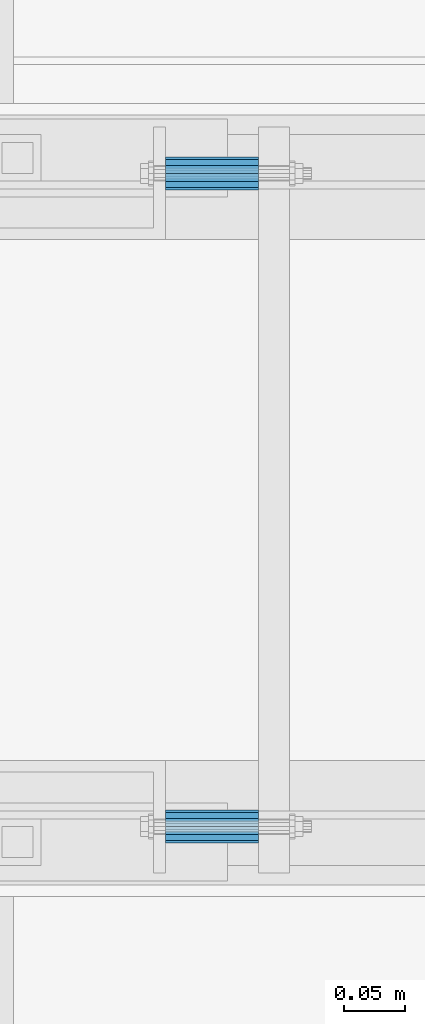
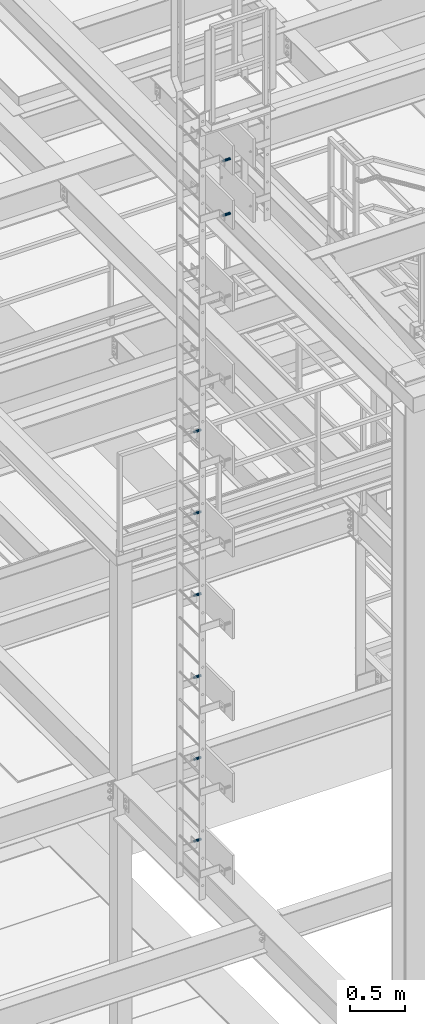
# One storey, part 2808 of 3843: 8 beams, 8 elements without a shape of their own.
"""IFC2X3 building model written with IfcOpenShell, lengths in millimetres."""

from ifc_helpers import new_model, si_unit, frame, origin_with_axes, place, context, subcontext, project, spatial, faceted_brep, material, type_object, element, aggregate, save


model = new_model("IFC2X3")

# Units and contexts
model_context = context("Model", 3, precision=1e-05, world=origin_with_axes())
body_context = subcontext(model_context, "Body", "Model", "MODEL_VIEW")
ifc_project = project(units=[si_unit("LENGTHUNIT", "METRE", prefix="MILLI"), si_unit("AREAUNIT", "SQUARE_METRE"), si_unit("VOLUMEUNIT", "CUBIC_METRE"), si_unit("MASSUNIT", "GRAM", prefix="KILO"), si_unit("TIMEUNIT", "SECOND"), si_unit("PLANEANGLEUNIT", "RADIAN"), si_unit("SOLIDANGLEUNIT", "STERADIAN"), si_unit("THERMODYNAMICTEMPERATUREUNIT", "DEGREE_CELSIUS"), si_unit("LUMINOUSINTENSITYUNIT", "LUMEN")], contexts=[model_context])

# Site, building, storey
site_placement = place(None, origin_with_axes())
site = spatial("IfcSite", under=ifc_project, at=site_placement, CompositionType="ELEMENT")
building_placement = place(site_placement, origin_with_axes())
building = spatial("IfcBuilding", under=site, at=building_placement, Name="Undefined", CompositionType="ELEMENT")
storey_placement = place(building_placement, origin_with_axes())
storey = spatial("IfcBuildingStorey", under=building, at=storey_placement, Name="Undefined", CompositionType="ELEMENT", Elevation=0.0)

# Assembly, beam
assembly_1_placement = place(storey_placement, origin_with_axes())
assembly_1 = element("IfcElementAssembly", 1, at=assembly_1_placement, inside=storey, Name="SLEEVE", AssemblyPlace="NOTDEFINED", PredefinedType="RIGID_FRAME")
ifc_material = material()
beam_type = type_object("IfcBeamType", Name="PIPE3/4SCH40", PredefinedType="NOTDEFINED")
beam_1_placement = place(assembly_1_placement, frame((48390.1749877929, 17919.6999999995, 35706.05), z_axis=(0.0, 0.0, 1.0), x_axis=(1.0, 0.0, 0.0)))
beam_1 = element("IfcBeam", 2, at=beam_1_placement, type_object=beam_type, material=ifc_material, Name="SLEEVE", ObjectType="PIPE3/4SCH40", context=body_context, shape_type="Brep", body=[
    faceted_brep([(0.0, -10.4648000000016, 7.27595761418343e-12), (-7.27595761418343e-12, -9.06278264552384, 5.23240000000806), (76.2000000004009, -9.06278264552384, 5.2324000001172), (76.2000000004045, -10.4648000000016, 1.16415321826935e-10), (-1.45519152283669e-11, -5.23240000000078, 9.06278264553839), (76.20000000039, -5.23240000000078, 9.06278264564753), (-1.45519152283669e-11, 0.0, 10.4648000000161), (76.20000000039, 0.0, 10.4648000001253), (-1.45519152283669e-11, 5.23240000000078, 9.06278264553839), (76.20000000039, 5.23240000000078, 9.06278264564753), (-7.27595761418343e-12, 9.06278264552384, 5.23240000000806), (76.2000000004009, 9.06278264552384, 5.2324000001172), (0.0, 10.4648000000016, 7.27595761418343e-12), (76.2000000004045, 10.4648000000016, 1.16415321826935e-10), (1.09139364212751e-11, 9.06278264552384, -5.2323999999935), (76.2000000004155, 9.06278264552384, -5.23239999988436), (1.45519152283669e-11, 5.23240000000078, -9.06278264551656), (76.2000000004191, 5.23240000000078, -9.06278264540742), (1.45519152283669e-11, 0.0, -10.4647999999943), (76.2000000004191, 0.0, -10.4647999998851), (1.45519152283669e-11, -5.23240000000078, -9.06278264551656), (76.2000000004191, -5.23240000000078, -9.06278264540742), (1.09139364212751e-11, -9.06278264552384, -5.2323999999935), (76.2000000004155, -9.06278264552384, -5.23239999988436), (0.0, -13.3349999999991, 7.27595761418343e-12), (1.09139364212751e-11, -11.5484487594658, -6.66749999999593), (76.2000000004155, -11.5484487594658, -6.66749999988679), (76.2000000004045, -13.3349999999991, 1.16415321826935e-10), (1.45519152283669e-11, -6.66749999999956, -11.5484487594586), (76.2000000004191, -6.66749999999956, -11.5484487593494), (1.81898940354586e-11, 0.0, -13.3349999999919), (76.2000000004227, 0.0, -13.3349999998827), (1.45519152283669e-11, 6.66749999999956, -11.5484487594586), (76.2000000004191, 6.66749999999956, -11.5484487593494), (1.09139364212751e-11, 11.5484487594658, -6.66749999999593), (76.2000000004155, 11.5484487594658, -6.66749999988679), (0.0, 13.3349999999991, 7.27595761418343e-12), (76.2000000004045, 13.3349999999991, 1.16415321826935e-10), (-7.27595761418343e-12, 11.5484487594658, 6.66750000001048), (76.2000000003973, 11.5484487594658, 6.66750000011234), (-1.45519152283669e-11, 6.66749999999956, 11.5484487594804), (76.20000000039, 6.66749999999956, 11.5484487595895), (-1.81898940354586e-11, 0.0, 13.3350000000137), (76.2000000003864, 0.0, 13.3350000001228), (-1.45519152283669e-11, -6.66749999999956, 11.5484487594804), (76.20000000039, -6.66749999999956, 11.5484487595895), (-7.27595761418343e-12, -11.5484487594658, 6.66750000001048), (76.2000000003973, -11.5484487594658, 6.66750000011234)], [[[0, 1, 2, 3]], [[1, 4, 5, 2]], [[4, 6, 7, 5]], [[6, 8, 9, 7]], [[8, 10, 11, 9]], [[10, 12, 13, 11]], [[12, 14, 15, 13]], [[14, 16, 17, 15]], [[16, 18, 19, 17]], [[18, 20, 21, 19]], [[20, 22, 23, 21]], [[22, 0, 3, 23]], [[24, 25, 26, 27]], [[25, 28, 29, 26]], [[28, 30, 31, 29]], [[30, 32, 33, 31]], [[32, 34, 35, 33]], [[34, 36, 37, 35]], [[36, 38, 39, 37]], [[38, 40, 41, 39]], [[40, 42, 43, 41]], [[42, 44, 45, 43]], [[44, 46, 47, 45]], [[46, 24, 27, 47]], [[29, 31, 33, 35, 37, 39, 41, 43, 45, 47, 27, 26], [5, 7, 9, 11, 13, 15, 17, 19, 21, 23, 3, 2]], [[46, 44, 42, 40, 38, 36, 34, 32, 30, 28, 25, 24], [22, 20, 18, 16, 14, 12, 10, 8, 6, 4, 1, 0]]]),
])
aggregate(assembly_1, [beam_1])

assembly_2_placement = place(storey_placement, origin_with_axes())
assembly_2 = element("IfcElementAssembly", 3, at=assembly_2_placement, inside=storey, Name="SLEEVE", AssemblyPlace="NOTDEFINED", PredefinedType="RIGID_FRAME")
beam_2_placement = place(assembly_2_placement, frame((48390.1749877929, 17919.6999999995, 36620.45), z_axis=(0.0, 0.0, 1.0), x_axis=(1.0, 0.0, 0.0)))
beam_2 = element("IfcBeam", 4, at=beam_2_placement, type_object=beam_type, material=ifc_material, Name="SLEEVE", ObjectType="PIPE3/4SCH40", context=body_context, shape_type="Brep", body=[
    faceted_brep([(0.0, -10.4648000000016, 7.27595761418343e-12), (-7.27595761418343e-12, -9.06278264552384, 5.23240000000806), (76.2000000004009, -9.06278264552384, 5.2324000001172), (76.2000000004045, -10.4648000000016, 1.16415321826935e-10), (-1.45519152283669e-11, -5.23240000000078, 9.06278264553839), (76.20000000039, -5.23240000000078, 9.06278264564753), (-1.45519152283669e-11, 0.0, 10.4648000000161), (76.20000000039, 0.0, 10.4648000001253), (-1.45519152283669e-11, 5.23240000000078, 9.06278264553839), (76.20000000039, 5.23240000000078, 9.06278264564753), (-7.27595761418343e-12, 9.06278264552384, 5.23240000000806), (76.2000000004009, 9.06278264552384, 5.2324000001172), (0.0, 10.4648000000016, 7.27595761418343e-12), (76.2000000004045, 10.4648000000016, 1.16415321826935e-10), (1.09139364212751e-11, 9.06278264552384, -5.2323999999935), (76.2000000004155, 9.06278264552384, -5.23239999988436), (1.45519152283669e-11, 5.23240000000078, -9.06278264551656), (76.2000000004191, 5.23240000000078, -9.06278264540742), (1.45519152283669e-11, 0.0, -10.4647999999943), (76.2000000004191, 0.0, -10.4647999998851), (1.45519152283669e-11, -5.23240000000078, -9.06278264551656), (76.2000000004191, -5.23240000000078, -9.06278264540742), (1.09139364212751e-11, -9.06278264552384, -5.2323999999935), (76.2000000004155, -9.06278264552384, -5.23239999988436), (0.0, -13.3349999999991, 7.27595761418343e-12), (1.09139364212751e-11, -11.5484487594658, -6.66749999999593), (76.2000000004155, -11.5484487594658, -6.66749999988679), (76.2000000004045, -13.3349999999991, 1.16415321826935e-10), (1.45519152283669e-11, -6.66749999999956, -11.5484487594586), (76.2000000004191, -6.66749999999956, -11.5484487593494), (1.81898940354586e-11, 0.0, -13.3349999999919), (76.2000000004227, 0.0, -13.3349999998827), (1.45519152283669e-11, 6.66749999999956, -11.5484487594586), (76.2000000004191, 6.66749999999956, -11.5484487593494), (1.09139364212751e-11, 11.5484487594658, -6.66749999999593), (76.2000000004155, 11.5484487594658, -6.66749999988679), (0.0, 13.3349999999991, 7.27595761418343e-12), (76.2000000004045, 13.3349999999991, 1.16415321826935e-10), (-7.27595761418343e-12, 11.5484487594658, 6.66750000001048), (76.2000000003973, 11.5484487594658, 6.66750000011234), (-1.45519152283669e-11, 6.66749999999956, 11.5484487594804), (76.20000000039, 6.66749999999956, 11.5484487595895), (-1.81898940354586e-11, 0.0, 13.3350000000137), (76.2000000003864, 0.0, 13.3350000001228), (-1.45519152283669e-11, -6.66749999999956, 11.5484487594804), (76.20000000039, -6.66749999999956, 11.5484487595895), (-7.27595761418343e-12, -11.5484487594658, 6.66750000001048), (76.2000000003973, -11.5484487594658, 6.66750000011234)], [[[0, 1, 2, 3]], [[1, 4, 5, 2]], [[4, 6, 7, 5]], [[6, 8, 9, 7]], [[8, 10, 11, 9]], [[10, 12, 13, 11]], [[12, 14, 15, 13]], [[14, 16, 17, 15]], [[16, 18, 19, 17]], [[18, 20, 21, 19]], [[20, 22, 23, 21]], [[22, 0, 3, 23]], [[24, 25, 26, 27]], [[25, 28, 29, 26]], [[28, 30, 31, 29]], [[30, 32, 33, 31]], [[32, 34, 35, 33]], [[34, 36, 37, 35]], [[36, 38, 39, 37]], [[38, 40, 41, 39]], [[40, 42, 43, 41]], [[42, 44, 45, 43]], [[44, 46, 47, 45]], [[46, 24, 27, 47]], [[29, 31, 33, 35, 37, 39, 41, 43, 45, 47, 27, 26], [5, 7, 9, 11, 13, 15, 17, 19, 21, 23, 3, 2]], [[46, 44, 42, 40, 38, 36, 34, 32, 30, 28, 25, 24], [22, 20, 18, 16, 14, 12, 10, 8, 6, 4, 1, 0]]]),
])
aggregate(assembly_2, [beam_2])

assembly_3_placement = place(storey_placement, origin_with_axes())
assembly_3 = element("IfcElementAssembly", 5, at=assembly_3_placement, inside=storey, Name="SLEEVE", AssemblyPlace="NOTDEFINED", PredefinedType="RIGID_FRAME")
beam_3_placement = place(assembly_3_placement, frame((48390.1749877929, 17919.6999999995, 37534.85), z_axis=(0.0, 0.0, 1.0), x_axis=(1.0, 0.0, 0.0)))
beam_3 = element("IfcBeam", 6, at=beam_3_placement, type_object=beam_type, material=ifc_material, Name="SLEEVE", ObjectType="PIPE3/4SCH40", context=body_context, shape_type="Brep", body=[
    faceted_brep([(0.0, -10.4648000000016, 7.27595761418343e-12), (-7.27595761418343e-12, -9.06278264552384, 5.23240000000806), (76.2000000004009, -9.06278264552384, 5.2324000001172), (76.2000000004045, -10.4648000000016, 1.16415321826935e-10), (-1.45519152283669e-11, -5.23240000000078, 9.06278264553839), (76.20000000039, -5.23240000000078, 9.06278264564753), (-1.45519152283669e-11, 0.0, 10.4648000000161), (76.20000000039, 0.0, 10.4648000001253), (-1.45519152283669e-11, 5.23240000000078, 9.06278264553839), (76.20000000039, 5.23240000000078, 9.06278264564753), (-7.27595761418343e-12, 9.06278264552384, 5.23240000000806), (76.2000000004009, 9.06278264552384, 5.2324000001172), (0.0, 10.4648000000016, 7.27595761418343e-12), (76.2000000004045, 10.4648000000016, 1.16415321826935e-10), (1.09139364212751e-11, 9.06278264552384, -5.2323999999935), (76.2000000004155, 9.06278264552384, -5.23239999988436), (1.45519152283669e-11, 5.23240000000078, -9.06278264551656), (76.2000000004191, 5.23240000000078, -9.06278264540742), (1.45519152283669e-11, 0.0, -10.4647999999943), (76.2000000004191, 0.0, -10.4647999998851), (1.45519152283669e-11, -5.23240000000078, -9.06278264551656), (76.2000000004191, -5.23240000000078, -9.06278264540742), (1.09139364212751e-11, -9.06278264552384, -5.2323999999935), (76.2000000004155, -9.06278264552384, -5.23239999988436), (0.0, -13.3349999999991, 7.27595761418343e-12), (1.09139364212751e-11, -11.5484487594658, -6.66749999999593), (76.2000000004155, -11.5484487594658, -6.66749999988679), (76.2000000004045, -13.3349999999991, 1.16415321826935e-10), (1.45519152283669e-11, -6.66749999999956, -11.5484487594586), (76.2000000004191, -6.66749999999956, -11.5484487593494), (1.81898940354586e-11, 0.0, -13.3349999999919), (76.2000000004227, 0.0, -13.3349999998827), (1.45519152283669e-11, 6.66749999999956, -11.5484487594586), (76.2000000004191, 6.66749999999956, -11.5484487593494), (1.09139364212751e-11, 11.5484487594658, -6.66749999999593), (76.2000000004155, 11.5484487594658, -6.66749999988679), (0.0, 13.3349999999991, 7.27595761418343e-12), (76.2000000004045, 13.3349999999991, 1.16415321826935e-10), (-7.27595761418343e-12, 11.5484487594658, 6.66750000001048), (76.2000000003973, 11.5484487594658, 6.66750000011234), (-1.45519152283669e-11, 6.66749999999956, 11.5484487594804), (76.20000000039, 6.66749999999956, 11.5484487595895), (-1.81898940354586e-11, 0.0, 13.3350000000137), (76.2000000003864, 0.0, 13.3350000001228), (-1.45519152283669e-11, -6.66749999999956, 11.5484487594804), (76.20000000039, -6.66749999999956, 11.5484487595895), (-7.27595761418343e-12, -11.5484487594658, 6.66750000001048), (76.2000000003973, -11.5484487594658, 6.66750000011234)], [[[0, 1, 2, 3]], [[1, 4, 5, 2]], [[4, 6, 7, 5]], [[6, 8, 9, 7]], [[8, 10, 11, 9]], [[10, 12, 13, 11]], [[12, 14, 15, 13]], [[14, 16, 17, 15]], [[16, 18, 19, 17]], [[18, 20, 21, 19]], [[20, 22, 23, 21]], [[22, 0, 3, 23]], [[24, 25, 26, 27]], [[25, 28, 29, 26]], [[28, 30, 31, 29]], [[30, 32, 33, 31]], [[32, 34, 35, 33]], [[34, 36, 37, 35]], [[36, 38, 39, 37]], [[38, 40, 41, 39]], [[40, 42, 43, 41]], [[42, 44, 45, 43]], [[44, 46, 47, 45]], [[46, 24, 27, 47]], [[29, 31, 33, 35, 37, 39, 41, 43, 45, 47, 27, 26], [5, 7, 9, 11, 13, 15, 17, 19, 21, 23, 3, 2]], [[46, 44, 42, 40, 38, 36, 34, 32, 30, 28, 25, 24], [22, 20, 18, 16, 14, 12, 10, 8, 6, 4, 1, 0]]]),
])
aggregate(assembly_3, [beam_3])

assembly_4_placement = place(storey_placement, origin_with_axes())
assembly_4 = element("IfcElementAssembly", 7, at=assembly_4_placement, inside=storey, Name="SLEEVE", AssemblyPlace="NOTDEFINED", PredefinedType="RIGID_FRAME")
beam_4_placement = place(assembly_4_placement, frame((48390.1749877929, 17919.6999999995, 38449.25), z_axis=(0.0, 0.0, 1.0), x_axis=(1.0, 0.0, 0.0)))
beam_4 = element("IfcBeam", 8, at=beam_4_placement, type_object=beam_type, material=ifc_material, Name="SLEEVE", ObjectType="PIPE3/4SCH40", context=body_context, shape_type="Brep", body=[
    faceted_brep([(0.0, -10.4648000000016, 7.27595761418343e-12), (-7.27595761418343e-12, -9.06278264552384, 5.23240000000806), (76.2000000004009, -9.06278264552384, 5.2324000001172), (76.2000000004045, -10.4648000000016, 1.16415321826935e-10), (-1.45519152283669e-11, -5.23240000000078, 9.06278264553839), (76.20000000039, -5.23240000000078, 9.06278264564753), (-1.45519152283669e-11, 0.0, 10.4648000000161), (76.20000000039, 0.0, 10.4648000001253), (-1.45519152283669e-11, 5.23240000000078, 9.06278264553839), (76.20000000039, 5.23240000000078, 9.06278264564753), (-7.27595761418343e-12, 9.06278264552384, 5.23240000000806), (76.2000000004009, 9.06278264552384, 5.2324000001172), (0.0, 10.4648000000016, 7.27595761418343e-12), (76.2000000004045, 10.4648000000016, 1.16415321826935e-10), (1.09139364212751e-11, 9.06278264552384, -5.2323999999935), (76.2000000004155, 9.06278264552384, -5.23239999988436), (1.45519152283669e-11, 5.23240000000078, -9.06278264551656), (76.2000000004191, 5.23240000000078, -9.06278264540742), (1.45519152283669e-11, 0.0, -10.4647999999943), (76.2000000004191, 0.0, -10.4647999998851), (1.45519152283669e-11, -5.23240000000078, -9.06278264551656), (76.2000000004191, -5.23240000000078, -9.06278264540742), (1.09139364212751e-11, -9.06278264552384, -5.2323999999935), (76.2000000004155, -9.06278264552384, -5.23239999988436), (0.0, -13.3349999999991, 7.27595761418343e-12), (1.09139364212751e-11, -11.5484487594658, -6.66749999999593), (76.2000000004155, -11.5484487594658, -6.66749999988679), (76.2000000004045, -13.3349999999991, 1.16415321826935e-10), (1.45519152283669e-11, -6.66749999999956, -11.5484487594586), (76.2000000004191, -6.66749999999956, -11.5484487593494), (1.81898940354586e-11, 0.0, -13.3349999999919), (76.2000000004227, 0.0, -13.3349999998827), (1.45519152283669e-11, 6.66749999999956, -11.5484487594586), (76.2000000004191, 6.66749999999956, -11.5484487593494), (1.09139364212751e-11, 11.5484487594658, -6.66749999999593), (76.2000000004155, 11.5484487594658, -6.66749999988679), (0.0, 13.3349999999991, 7.27595761418343e-12), (76.2000000004045, 13.3349999999991, 1.16415321826935e-10), (-7.27595761418343e-12, 11.5484487594658, 6.66750000001048), (76.2000000003973, 11.5484487594658, 6.66750000011234), (-1.45519152283669e-11, 6.66749999999956, 11.5484487594804), (76.20000000039, 6.66749999999956, 11.5484487595895), (-1.81898940354586e-11, 0.0, 13.3350000000137), (76.2000000003864, 0.0, 13.3350000001228), (-1.45519152283669e-11, -6.66749999999956, 11.5484487594804), (76.20000000039, -6.66749999999956, 11.5484487595895), (-7.27595761418343e-12, -11.5484487594658, 6.66750000001048), (76.2000000003973, -11.5484487594658, 6.66750000011234)], [[[0, 1, 2, 3]], [[1, 4, 5, 2]], [[4, 6, 7, 5]], [[6, 8, 9, 7]], [[8, 10, 11, 9]], [[10, 12, 13, 11]], [[12, 14, 15, 13]], [[14, 16, 17, 15]], [[16, 18, 19, 17]], [[18, 20, 21, 19]], [[20, 22, 23, 21]], [[22, 0, 3, 23]], [[24, 25, 26, 27]], [[25, 28, 29, 26]], [[28, 30, 31, 29]], [[30, 32, 33, 31]], [[32, 34, 35, 33]], [[34, 36, 37, 35]], [[36, 38, 39, 37]], [[38, 40, 41, 39]], [[40, 42, 43, 41]], [[42, 44, 45, 43]], [[44, 46, 47, 45]], [[46, 24, 27, 47]], [[29, 31, 33, 35, 37, 39, 41, 43, 45, 47, 27, 26], [5, 7, 9, 11, 13, 15, 17, 19, 21, 23, 3, 2]], [[46, 44, 42, 40, 38, 36, 34, 32, 30, 28, 25, 24], [22, 20, 18, 16, 14, 12, 10, 8, 6, 4, 1, 0]]]),
])
aggregate(assembly_4, [beam_4])

assembly_5_placement = place(storey_placement, origin_with_axes())
assembly_5 = element("IfcElementAssembly", 9, at=assembly_5_placement, inside=storey, Name="SLEEVE", AssemblyPlace="NOTDEFINED", PredefinedType="RIGID_FRAME")
beam_5_placement = place(assembly_5_placement, frame((48390.1749877929, 17919.6999999995, 39363.65), z_axis=(0.0, 0.0, 1.0), x_axis=(1.0, 0.0, 0.0)))
beam_5 = element("IfcBeam", 10, at=beam_5_placement, type_object=beam_type, material=ifc_material, Name="SLEEVE", ObjectType="PIPE3/4SCH40", context=body_context, shape_type="Brep", body=[
    faceted_brep([(0.0, -10.4648000000016, 7.27595761418343e-12), (-7.27595761418343e-12, -9.06278264552384, 5.23240000000806), (76.2000000004009, -9.06278264552384, 5.2324000001172), (76.2000000004045, -10.4648000000016, 1.16415321826935e-10), (-1.45519152283669e-11, -5.23240000000078, 9.06278264553839), (76.20000000039, -5.23240000000078, 9.06278264564753), (-1.45519152283669e-11, 0.0, 10.4648000000161), (76.20000000039, 0.0, 10.4648000001253), (-1.45519152283669e-11, 5.23240000000078, 9.06278264553839), (76.20000000039, 5.23240000000078, 9.06278264564753), (-7.27595761418343e-12, 9.06278264552384, 5.23240000000806), (76.2000000004009, 9.06278264552384, 5.2324000001172), (0.0, 10.4648000000016, 7.27595761418343e-12), (76.2000000004045, 10.4648000000016, 1.16415321826935e-10), (1.09139364212751e-11, 9.06278264552384, -5.2323999999935), (76.2000000004155, 9.06278264552384, -5.23239999988436), (1.45519152283669e-11, 5.23240000000078, -9.06278264551656), (76.2000000004191, 5.23240000000078, -9.06278264540742), (1.45519152283669e-11, 0.0, -10.4647999999943), (76.2000000004191, 0.0, -10.4647999998851), (1.45519152283669e-11, -5.23240000000078, -9.06278264551656), (76.2000000004191, -5.23240000000078, -9.06278264540742), (1.09139364212751e-11, -9.06278264552384, -5.2323999999935), (76.2000000004155, -9.06278264552384, -5.23239999988436), (0.0, -13.3349999999991, 7.27595761418343e-12), (1.09139364212751e-11, -11.5484487594658, -6.66749999999593), (76.2000000004155, -11.5484487594658, -6.66749999988679), (76.2000000004045, -13.3349999999991, 1.16415321826935e-10), (1.45519152283669e-11, -6.66749999999956, -11.5484487594586), (76.2000000004191, -6.66749999999956, -11.5484487593494), (1.81898940354586e-11, 0.0, -13.3349999999919), (76.2000000004227, 0.0, -13.3349999998827), (1.45519152283669e-11, 6.66749999999956, -11.5484487594586), (76.2000000004191, 6.66749999999956, -11.5484487593494), (1.09139364212751e-11, 11.5484487594658, -6.66749999999593), (76.2000000004155, 11.5484487594658, -6.66749999988679), (0.0, 13.3349999999991, 7.27595761418343e-12), (76.2000000004045, 13.3349999999991, 1.16415321826935e-10), (-7.27595761418343e-12, 11.5484487594658, 6.66750000001048), (76.2000000003973, 11.5484487594658, 6.66750000011234), (-1.45519152283669e-11, 6.66749999999956, 11.5484487594804), (76.20000000039, 6.66749999999956, 11.5484487595895), (-1.81898940354586e-11, 0.0, 13.3350000000137), (76.2000000003864, 0.0, 13.3350000001228), (-1.45519152283669e-11, -6.66749999999956, 11.5484487594804), (76.20000000039, -6.66749999999956, 11.5484487595895), (-7.27595761418343e-12, -11.5484487594658, 6.66750000001048), (76.2000000003973, -11.5484487594658, 6.66750000011234)], [[[0, 1, 2, 3]], [[1, 4, 5, 2]], [[4, 6, 7, 5]], [[6, 8, 9, 7]], [[8, 10, 11, 9]], [[10, 12, 13, 11]], [[12, 14, 15, 13]], [[14, 16, 17, 15]], [[16, 18, 19, 17]], [[18, 20, 21, 19]], [[20, 22, 23, 21]], [[22, 0, 3, 23]], [[24, 25, 26, 27]], [[25, 28, 29, 26]], [[28, 30, 31, 29]], [[30, 32, 33, 31]], [[32, 34, 35, 33]], [[34, 36, 37, 35]], [[36, 38, 39, 37]], [[38, 40, 41, 39]], [[40, 42, 43, 41]], [[42, 44, 45, 43]], [[44, 46, 47, 45]], [[46, 24, 27, 47]], [[29, 31, 33, 35, 37, 39, 41, 43, 45, 47, 27, 26], [5, 7, 9, 11, 13, 15, 17, 19, 21, 23, 3, 2]], [[46, 44, 42, 40, 38, 36, 34, 32, 30, 28, 25, 24], [22, 20, 18, 16, 14, 12, 10, 8, 6, 4, 1, 0]]]),
])
aggregate(assembly_5, [beam_5])

assembly_6_placement = place(storey_placement, origin_with_axes())
assembly_6 = element("IfcElementAssembly", 11, at=assembly_6_placement, inside=storey, Name="SLEEVE", AssemblyPlace="NOTDEFINED", PredefinedType="RIGID_FRAME")
beam_6_placement = place(assembly_6_placement, frame((48390.1749877929, 17919.6999999995, 40278.05), z_axis=(0.0, 0.0, 1.0), x_axis=(1.0, 0.0, 0.0)))
beam_6 = element("IfcBeam", 12, at=beam_6_placement, type_object=beam_type, material=ifc_material, Name="SLEEVE", ObjectType="PIPE3/4SCH40", context=body_context, shape_type="Brep", body=[
    faceted_brep([(0.0, -10.4648000000016, 7.27595761418343e-12), (-7.27595761418343e-12, -9.06278264552384, 5.23240000000806), (76.2000000004009, -9.06278264552384, 5.2324000001172), (76.2000000004045, -10.4648000000016, 1.16415321826935e-10), (-1.45519152283669e-11, -5.23240000000078, 9.06278264553839), (76.20000000039, -5.23240000000078, 9.06278264564753), (-1.45519152283669e-11, 0.0, 10.4648000000161), (76.20000000039, 0.0, 10.4648000001253), (-1.45519152283669e-11, 5.23240000000078, 9.06278264553839), (76.20000000039, 5.23240000000078, 9.06278264564753), (-7.27595761418343e-12, 9.06278264552384, 5.23240000000806), (76.2000000004009, 9.06278264552384, 5.2324000001172), (0.0, 10.4648000000016, 7.27595761418343e-12), (76.2000000004045, 10.4648000000016, 1.16415321826935e-10), (1.09139364212751e-11, 9.06278264552384, -5.2323999999935), (76.2000000004155, 9.06278264552384, -5.23239999988436), (1.45519152283669e-11, 5.23240000000078, -9.06278264551656), (76.2000000004191, 5.23240000000078, -9.06278264540742), (1.45519152283669e-11, 0.0, -10.4647999999943), (76.2000000004191, 0.0, -10.4647999998851), (1.45519152283669e-11, -5.23240000000078, -9.06278264551656), (76.2000000004191, -5.23240000000078, -9.06278264540742), (1.09139364212751e-11, -9.06278264552384, -5.2323999999935), (76.2000000004155, -9.06278264552384, -5.23239999988436), (0.0, -13.3349999999991, 7.27595761418343e-12), (1.09139364212751e-11, -11.5484487594658, -6.66749999999593), (76.2000000004155, -11.5484487594658, -6.66749999988679), (76.2000000004045, -13.3349999999991, 1.16415321826935e-10), (1.45519152283669e-11, -6.66749999999956, -11.5484487594586), (76.2000000004191, -6.66749999999956, -11.5484487593494), (1.81898940354586e-11, 0.0, -13.3349999999919), (76.2000000004227, 0.0, -13.3349999998827), (1.45519152283669e-11, 6.66749999999956, -11.5484487594586), (76.2000000004191, 6.66749999999956, -11.5484487593494), (1.09139364212751e-11, 11.5484487594658, -6.66749999999593), (76.2000000004155, 11.5484487594658, -6.66749999988679), (0.0, 13.3349999999991, 7.27595761418343e-12), (76.2000000004045, 13.3349999999991, 1.16415321826935e-10), (-7.27595761418343e-12, 11.5484487594658, 6.66750000001048), (76.2000000003973, 11.5484487594658, 6.66750000011234), (-1.45519152283669e-11, 6.66749999999956, 11.5484487594804), (76.20000000039, 6.66749999999956, 11.5484487595895), (-1.81898940354586e-11, 0.0, 13.3350000000137), (76.2000000003864, 0.0, 13.3350000001228), (-1.45519152283669e-11, -6.66749999999956, 11.5484487594804), (76.20000000039, -6.66749999999956, 11.5484487595895), (-7.27595761418343e-12, -11.5484487594658, 6.66750000001048), (76.2000000003973, -11.5484487594658, 6.66750000011234)], [[[0, 1, 2, 3]], [[1, 4, 5, 2]], [[4, 6, 7, 5]], [[6, 8, 9, 7]], [[8, 10, 11, 9]], [[10, 12, 13, 11]], [[12, 14, 15, 13]], [[14, 16, 17, 15]], [[16, 18, 19, 17]], [[18, 20, 21, 19]], [[20, 22, 23, 21]], [[22, 0, 3, 23]], [[24, 25, 26, 27]], [[25, 28, 29, 26]], [[28, 30, 31, 29]], [[30, 32, 33, 31]], [[32, 34, 35, 33]], [[34, 36, 37, 35]], [[36, 38, 39, 37]], [[38, 40, 41, 39]], [[40, 42, 43, 41]], [[42, 44, 45, 43]], [[44, 46, 47, 45]], [[46, 24, 27, 47]], [[29, 31, 33, 35, 37, 39, 41, 43, 45, 47, 27, 26], [5, 7, 9, 11, 13, 15, 17, 19, 21, 23, 3, 2]], [[46, 44, 42, 40, 38, 36, 34, 32, 30, 28, 25, 24], [22, 20, 18, 16, 14, 12, 10, 8, 6, 4, 1, 0]]]),
])
aggregate(assembly_6, [beam_6])

assembly_7_placement = place(storey_placement, origin_with_axes())
assembly_7 = element("IfcElementAssembly", 13, at=assembly_7_placement, inside=storey, Name="SLEEVE", AssemblyPlace="NOTDEFINED", PredefinedType="RIGID_FRAME")
beam_7_placement = place(assembly_7_placement, frame((48390.1749877929, 17386.3, 43021.25), z_axis=(0.0, 0.0, 1.0), x_axis=(1.0, 0.0, 0.0)))
beam_7 = element("IfcBeam", 14, at=beam_7_placement, type_object=beam_type, material=ifc_material, Name="SLEEVE", ObjectType="PIPE3/4SCH40", context=body_context, shape_type="Brep", body=[
    faceted_brep([(0.0, -10.4648000000016, 7.27595761418343e-12), (-7.27595761418343e-12, -9.06278264552384, 5.23240000000806), (76.2000000004009, -9.06278264552384, 5.2324000001172), (76.2000000004045, -10.4648000000016, 1.16415321826935e-10), (-1.45519152283669e-11, -5.23240000000078, 9.06278264553839), (76.20000000039, -5.23240000000078, 9.06278264564753), (-1.45519152283669e-11, 0.0, 10.4648000000161), (76.20000000039, 0.0, 10.4648000001253), (-1.45519152283669e-11, 5.23240000000078, 9.06278264553839), (76.20000000039, 5.23240000000078, 9.06278264564753), (-7.27595761418343e-12, 9.06278264552384, 5.23240000000806), (76.2000000004009, 9.06278264552384, 5.2324000001172), (0.0, 10.4648000000016, 7.27595761418343e-12), (76.2000000004045, 10.4648000000016, 1.16415321826935e-10), (1.09139364212751e-11, 9.06278264552384, -5.2323999999935), (76.2000000004155, 9.06278264552384, -5.23239999988436), (1.45519152283669e-11, 5.23240000000078, -9.06278264551656), (76.2000000004191, 5.23240000000078, -9.06278264540742), (1.45519152283669e-11, 0.0, -10.4647999999943), (76.2000000004191, 0.0, -10.4647999998851), (1.45519152283669e-11, -5.23240000000078, -9.06278264551656), (76.2000000004191, -5.23240000000078, -9.06278264540742), (1.09139364212751e-11, -9.06278264552384, -5.2323999999935), (76.2000000004155, -9.06278264552384, -5.23239999988436), (0.0, -13.3349999999991, 7.27595761418343e-12), (1.09139364212751e-11, -11.5484487594658, -6.66749999999593), (76.2000000004155, -11.5484487594658, -6.66749999988679), (76.2000000004045, -13.3349999999991, 1.16415321826935e-10), (1.45519152283669e-11, -6.66749999999956, -11.5484487594586), (76.2000000004191, -6.66749999999956, -11.5484487593494), (1.81898940354586e-11, 0.0, -13.3349999999919), (76.2000000004227, 0.0, -13.3349999998827), (1.45519152283669e-11, 6.66749999999956, -11.5484487594586), (76.2000000004191, 6.66749999999956, -11.5484487593494), (1.09139364212751e-11, 11.5484487594658, -6.66749999999593), (76.2000000004155, 11.5484487594658, -6.66749999988679), (0.0, 13.3349999999991, 7.27595761418343e-12), (76.2000000004045, 13.3349999999991, 1.16415321826935e-10), (-7.27595761418343e-12, 11.5484487594658, 6.66750000001048), (76.2000000003973, 11.5484487594658, 6.66750000011234), (-1.45519152283669e-11, 6.66749999999956, 11.5484487594804), (76.20000000039, 6.66749999999956, 11.5484487595895), (-1.81898940354586e-11, 0.0, 13.3350000000137), (76.2000000003864, 0.0, 13.3350000001228), (-1.45519152283669e-11, -6.66749999999956, 11.5484487594804), (76.20000000039, -6.66749999999956, 11.5484487595895), (-7.27595761418343e-12, -11.5484487594658, 6.66750000001048), (76.2000000003973, -11.5484487594658, 6.66750000011234)], [[[0, 1, 2, 3]], [[1, 4, 5, 2]], [[4, 6, 7, 5]], [[6, 8, 9, 7]], [[8, 10, 11, 9]], [[10, 12, 13, 11]], [[12, 14, 15, 13]], [[14, 16, 17, 15]], [[16, 18, 19, 17]], [[18, 20, 21, 19]], [[20, 22, 23, 21]], [[22, 0, 3, 23]], [[24, 25, 26, 27]], [[25, 28, 29, 26]], [[28, 30, 31, 29]], [[30, 32, 33, 31]], [[32, 34, 35, 33]], [[34, 36, 37, 35]], [[36, 38, 39, 37]], [[38, 40, 41, 39]], [[40, 42, 43, 41]], [[42, 44, 45, 43]], [[44, 46, 47, 45]], [[46, 24, 27, 47]], [[29, 31, 33, 35, 37, 39, 41, 43, 45, 47, 27, 26], [5, 7, 9, 11, 13, 15, 17, 19, 21, 23, 3, 2]], [[46, 44, 42, 40, 38, 36, 34, 32, 30, 28, 25, 24], [22, 20, 18, 16, 14, 12, 10, 8, 6, 4, 1, 0]]]),
])
aggregate(assembly_7, [beam_7])

assembly_8_placement = place(storey_placement, origin_with_axes())
assembly_8 = element("IfcElementAssembly", 15, at=assembly_8_placement, inside=storey, Name="SLEEVE", AssemblyPlace="NOTDEFINED", PredefinedType="RIGID_FRAME")
beam_8_placement = place(assembly_8_placement, frame((48390.1749877929, 17386.3, 43630.85), z_axis=(0.0, 0.0, 1.0), x_axis=(1.0, 0.0, 0.0)))
beam_8 = element("IfcBeam", 16, at=beam_8_placement, type_object=beam_type, material=ifc_material, Name="SLEEVE", ObjectType="PIPE3/4SCH40", context=body_context, shape_type="Brep", body=[
    faceted_brep([(0.0, -10.4648000000016, 7.27595761418343e-12), (-7.27595761418343e-12, -9.06278264552384, 5.23240000000806), (76.2000000004009, -9.06278264552384, 5.2324000001172), (76.2000000004045, -10.4648000000016, 1.16415321826935e-10), (-1.45519152283669e-11, -5.23240000000078, 9.06278264553839), (76.20000000039, -5.23240000000078, 9.06278264564753), (-1.45519152283669e-11, 0.0, 10.4648000000161), (76.20000000039, 0.0, 10.4648000001253), (-1.45519152283669e-11, 5.23240000000078, 9.06278264553839), (76.20000000039, 5.23240000000078, 9.06278264564753), (-7.27595761418343e-12, 9.06278264552384, 5.23240000000806), (76.2000000004009, 9.06278264552384, 5.2324000001172), (0.0, 10.4648000000016, 7.27595761418343e-12), (76.2000000004045, 10.4648000000016, 1.16415321826935e-10), (1.09139364212751e-11, 9.06278264552384, -5.2323999999935), (76.2000000004155, 9.06278264552384, -5.23239999988436), (1.45519152283669e-11, 5.23240000000078, -9.06278264551656), (76.2000000004191, 5.23240000000078, -9.06278264540742), (1.45519152283669e-11, 0.0, -10.4647999999943), (76.2000000004191, 0.0, -10.4647999998851), (1.45519152283669e-11, -5.23240000000078, -9.06278264551656), (76.2000000004191, -5.23240000000078, -9.06278264540742), (1.09139364212751e-11, -9.06278264552384, -5.2323999999935), (76.2000000004155, -9.06278264552384, -5.23239999988436), (0.0, -13.3349999999991, 7.27595761418343e-12), (1.09139364212751e-11, -11.5484487594658, -6.66749999999593), (76.2000000004155, -11.5484487594658, -6.66749999988679), (76.2000000004045, -13.3349999999991, 1.16415321826935e-10), (1.45519152283669e-11, -6.66749999999956, -11.5484487594586), (76.2000000004191, -6.66749999999956, -11.5484487593494), (1.81898940354586e-11, 0.0, -13.3349999999919), (76.2000000004227, 0.0, -13.3349999998827), (1.45519152283669e-11, 6.66749999999956, -11.5484487594586), (76.2000000004191, 6.66749999999956, -11.5484487593494), (1.09139364212751e-11, 11.5484487594658, -6.66749999999593), (76.2000000004155, 11.5484487594658, -6.66749999988679), (0.0, 13.3349999999991, 7.27595761418343e-12), (76.2000000004045, 13.3349999999991, 1.16415321826935e-10), (-7.27595761418343e-12, 11.5484487594658, 6.66750000001048), (76.2000000003973, 11.5484487594658, 6.66750000011234), (-1.45519152283669e-11, 6.66749999999956, 11.5484487594804), (76.20000000039, 6.66749999999956, 11.5484487595895), (-1.81898940354586e-11, 0.0, 13.3350000000137), (76.2000000003864, 0.0, 13.3350000001228), (-1.45519152283669e-11, -6.66749999999956, 11.5484487594804), (76.20000000039, -6.66749999999956, 11.5484487595895), (-7.27595761418343e-12, -11.5484487594658, 6.66750000001048), (76.2000000003973, -11.5484487594658, 6.66750000011234)], [[[0, 1, 2, 3]], [[1, 4, 5, 2]], [[4, 6, 7, 5]], [[6, 8, 9, 7]], [[8, 10, 11, 9]], [[10, 12, 13, 11]], [[12, 14, 15, 13]], [[14, 16, 17, 15]], [[16, 18, 19, 17]], [[18, 20, 21, 19]], [[20, 22, 23, 21]], [[22, 0, 3, 23]], [[24, 25, 26, 27]], [[25, 28, 29, 26]], [[28, 30, 31, 29]], [[30, 32, 33, 31]], [[32, 34, 35, 33]], [[34, 36, 37, 35]], [[36, 38, 39, 37]], [[38, 40, 41, 39]], [[40, 42, 43, 41]], [[42, 44, 45, 43]], [[44, 46, 47, 45]], [[46, 24, 27, 47]], [[29, 31, 33, 35, 37, 39, 41, 43, 45, 47, 27, 26], [5, 7, 9, 11, 13, 15, 17, 19, 21, 23, 3, 2]], [[46, 44, 42, 40, 38, 36, 34, 32, 30, 28, 25, 24], [22, 20, 18, 16, 14, 12, 10, 8, 6, 4, 1, 0]]]),
])
aggregate(assembly_8, [beam_8])

save(model, "model.ifc")
